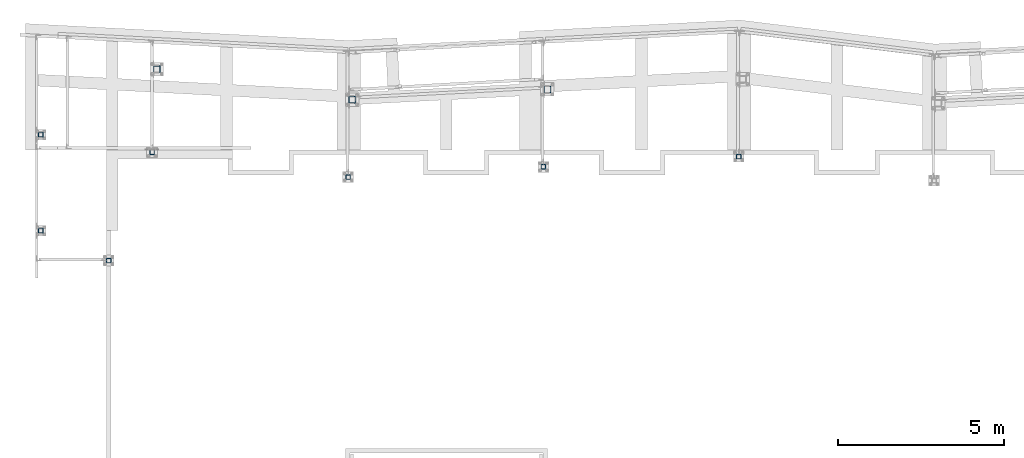
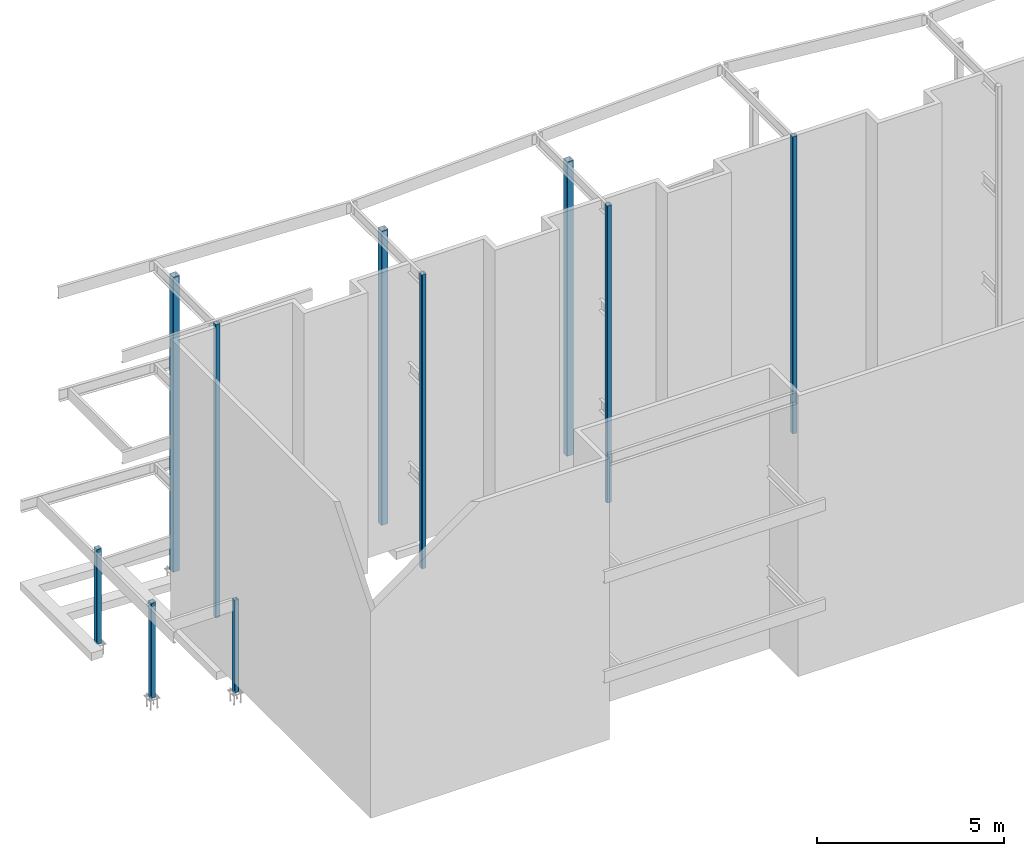
# One storey, part 1 of 89: 10 columns.
"""IFC4 building model written with IfcOpenShell, lengths in feet."""

from ifc_helpers import new_model, entity, si_unit, converted_unit, derived_unit, direction, frame, origin, place, context, subcontext, project, spatial, polyline, outline, extrude, boolean, source, transform, mapped, material, type_object, type_shapes, element, save


model = new_model("IFC4")

# Units and contexts
model_context = context("Model", 3, precision=0.0001, world=origin(), true_north=direction((6.12303176911189e-17, 1.0)))
body_context = subcontext(model_context, "Body", "Model", "MODEL_VIEW")
ifc_project = project(units=[converted_unit("LENGTHUNIT", "FOOT", entity("IfcRatioMeasure", 0.3048), si_unit("LENGTHUNIT", "METRE"), dimensions=[1, 0, 0, 0, 0, 0, 0]), converted_unit("AREAUNIT", "SQUARE FOOT", entity("IfcRatioMeasure", 0.09290304), si_unit("AREAUNIT", "SQUARE_METRE"), dimensions=[2, 0, 0, 0, 0, 0, 0]), converted_unit("VOLUMEUNIT", "CUBIC FOOT", entity("IfcRatioMeasure", 0.028316846592), si_unit("VOLUMEUNIT", "CUBIC_METRE"), dimensions=[3, 0, 0, 0, 0, 0, 0]), si_unit("PLANEANGLEUNIT", "RADIAN"), si_unit("MASSUNIT", "GRAM", prefix="KILO"), derived_unit("MASSDENSITYUNIT", [(si_unit("MASSUNIT", "GRAM", prefix="KILO"), 1), (si_unit("LENGTHUNIT", "METRE"), -3)]), derived_unit("MOMENTOFINERTIAUNIT", [(si_unit("LENGTHUNIT", "METRE"), 4)]), si_unit("TIMEUNIT", "SECOND"), si_unit("FREQUENCYUNIT", "HERTZ"), si_unit("THERMODYNAMICTEMPERATUREUNIT", "DEGREE_CELSIUS"), derived_unit("THERMALTRANSMITTANCEUNIT", [(si_unit("MASSUNIT", "GRAM", prefix="KILO"), 1), (si_unit("THERMODYNAMICTEMPERATUREUNIT", "KELVIN"), -1), (si_unit("TIMEUNIT", "SECOND"), -3)]), derived_unit("VOLUMETRICFLOWRATEUNIT", [(si_unit("LENGTHUNIT", "METRE"), 3), (si_unit("TIMEUNIT", "SECOND"), -1)]), si_unit("ELECTRICCURRENTUNIT", "AMPERE"), si_unit("ELECTRICVOLTAGEUNIT", "VOLT"), si_unit("POWERUNIT", "WATT"), si_unit("FORCEUNIT", "NEWTON"), si_unit("ILLUMINANCEUNIT", "LUX"), si_unit("LUMINOUSFLUXUNIT", "LUMEN"), si_unit("LUMINOUSINTENSITYUNIT", "CANDELA"), derived_unit("USERDEFINED", [(si_unit("MASSUNIT", "GRAM", prefix="KILO"), -1), (si_unit("LENGTHUNIT", "METRE"), -2), (si_unit("TIMEUNIT", "SECOND"), 3), (si_unit("LUMINOUSFLUXUNIT", "LUMEN"), 1)]), derived_unit("LINEARVELOCITYUNIT", [(si_unit("LENGTHUNIT", "METRE"), 1), (si_unit("TIMEUNIT", "SECOND"), -1)]), si_unit("PRESSUREUNIT", "PASCAL"), derived_unit("USERDEFINED", [(si_unit("LENGTHUNIT", "METRE"), -2), (si_unit("MASSUNIT", "GRAM", prefix="KILO"), 1), (si_unit("TIMEUNIT", "SECOND"), -2)]), derived_unit("LINEARFORCEUNIT", [(si_unit("MASSUNIT", "GRAM", prefix="KILO"), 1), (si_unit("LENGTHUNIT", "METRE"), 1), (si_unit("TIMEUNIT", "SECOND"), -2), (si_unit("LENGTHUNIT", "METRE"), -1)]), derived_unit("PLANARFORCEUNIT", [(si_unit("MASSUNIT", "GRAM", prefix="KILO"), 1), (si_unit("LENGTHUNIT", "METRE"), 1), (si_unit("TIMEUNIT", "SECOND"), -2), (si_unit("LENGTHUNIT", "METRE"), -2)])], contexts=[model_context])

# Site, building, storey
site_placement = place(None, origin())
site = spatial("IfcSite", under=ifc_project, at=site_placement, CompositionType="ELEMENT")
building_placement = place(site_placement, frame((-472.238160486, -49.138065117, 0.0)))
building = spatial("IfcBuilding", under=site, at=building_placement, CompositionType="ELEMENT")
storey_placement = place(building_placement, origin())
storey = spatial("IfcBuildingStorey", under=building, at=storey_placement, Name="Level 1", CompositionType="ELEMENT", Elevation=0.0)

# Columns
ifc_material = material(Name="Color 7719", Category="Materials")
column_type_1 = type_object("IfcColumnType", Name="hss17", PredefinedType="COLUMN")
shared_shape_1 = source(origin(), body_context, "Body", "CSG", [
    boolean("DIFFERENCE", extrude(outline(polyline([(-0.270833333333371, -0.333333333333371), (0.270833333333371, -0.333333333333371), (0.294751047856153, -0.328575804115331), (0.315027507157538, -0.315027507157509), (0.328575804115303, -0.294751047856181), (0.333333333333371, -0.270833333333371), (0.333333333333371, 0.270833333333314), (0.328575804115303, 0.294751047856124), (0.315027507157538, 0.315027507157453), (0.294751047856153, 0.328575804115275), (0.270833333333371, 0.333333333333314), (-0.270833333333371, 0.333333333333314), (-0.294751047856153, 0.328575804115275), (-0.315027507157538, 0.315027507157453), (-0.328575804115303, 0.294751047856124), (-0.333333333333371, 0.270833333333314), (-0.333333333333371, -0.270833333333371), (-0.328575804115303, -0.294751047856181), (-0.315027507157538, -0.315027507157509), (-0.294751047856153, -0.328575804115331), (-0.270833333333371, -0.333333333333371)])), frame((211.5, 1016.0, -0.479166666666668), z_axis=(0.0, 0.0, 1.0), x_axis=(0.0, -1.0, 0.0)), (0.0, 0.0, 1.0), 31.5416666666667), extrude(outline(polyline([(-0.270833333333599, -0.302083333333343), (0.270833333333144, -0.302083333333343), (0.282792190594478, -0.299704568724309), (0.29293042024517, -0.292930420245426), (0.29970456872411, -0.282792190594733), (0.302083333333144, -0.270833333333343), (0.302083333333144, 0.270833333333343), (0.29970456872411, 0.282792190594733), (0.29293042024517, 0.292930420245426), (0.282792190594478, 0.299704568724309), (0.270833333333144, 0.302083333333343), (-0.270833333333599, 0.302083333333343), (-0.282792190594932, 0.299704568724309), (-0.292930420245625, 0.292930420245426), (-0.299704568724565, 0.282792190594733), (-0.302083333333599, 0.270833333333343), (-0.302083333333599, -0.270833333333343), (-0.299704568724565, -0.282792190594733), (-0.292930420245625, -0.292930420245426), (-0.282792190594932, -0.299704568724309), (-0.270833333333599, -0.302083333333343)])), frame((211.5, 1016.0, 31.0625), z_axis=(0.0, 0.0, -1.0), x_axis=(0.0, -1.0, 0.0)), (0.0, 0.0, 1.0), 31.5416666666667)),
])
type_shapes(column_type_1, [shared_shape_1])
column_1_placement = place(building_placement, origin())
element("IfcColumn", 1, at=column_1_placement, inside=storey, type_object=column_type_1, material=ifc_material, Name="hss17:hss17", ObjectType="hss17:hss17", PredefinedType="COLUMN", context=body_context, shape_type="MappedRepresentation", body=[
    mapped(shared_shape_1, transform((0.0, 0.0, 0.0), scale=1.0)),
])
column_type_2 = type_object("IfcColumnType", Name="hss24", PredefinedType="COLUMN")
shared_shape_2 = source(origin(), body_context, "Body", "CSG", [
    boolean("DIFFERENCE", extrude(outline(polyline([(-0.187499999999886, -0.250000000000028), (0.187500000000114, -0.250000000000028), (0.211417714522895, -0.245242470781989), (0.23169417382428, -0.231694173824195), (0.245242470782046, -0.211417714522838), (0.250000000000114, -0.187500000000028), (0.250000000000114, 0.187499999999972), (0.245242470782046, 0.211417714522781), (0.23169417382428, 0.231694173824138), (0.211417714522895, 0.245242470781932), (0.187500000000114, 0.249999999999972), (-0.187499999999886, 0.249999999999972), (-0.211417714522668, 0.245242470781932), (-0.231694173824053, 0.231694173824138), (-0.245242470781818, 0.211417714522781), (-0.249999999999886, 0.187499999999972), (-0.249999999999886, -0.187500000000028), (-0.245242470781818, -0.211417714522838), (-0.231694173824053, -0.231694173824195), (-0.211417714522668, -0.245242470781989), (-0.187499999999886, -0.250000000000028)])), frame((200.0, 1009.5, -0.291666666666667), z_axis=(0.0, 0.0, 1.0), x_axis=(0.0, -1.0, 0.0)), (0.0, 0.0, 1.0), 10.1458333333333), extrude(outline(polyline([(-0.1875, -0.218749999999972), (0.1875, -0.218749999999972), (0.199458857261448, -0.216371235390938), (0.209597086912027, -0.209597086912055), (0.216371235390966, -0.199458857261391), (0.21875, -0.187499999999972), (0.21875, 0.187500000000028), (0.216371235390966, 0.199458857261448), (0.209597086912027, 0.209597086912112), (0.199458857261448, 0.216371235390994), (0.1875, 0.218750000000028), (-0.1875, 0.218750000000028), (-0.199458857261448, 0.216371235390994), (-0.209597086912027, 0.209597086912112), (-0.216371235390966, 0.199458857261448), (-0.21875, 0.187500000000028), (-0.21875, -0.187499999999972), (-0.216371235390966, -0.199458857261391), (-0.209597086912027, -0.209597086912055), (-0.199458857261448, -0.216371235390938), (-0.1875, -0.218749999999972)])), frame((200.0, 1009.5, 9.85416666666663), z_axis=(0.0, 0.0, -1.0), x_axis=(0.0, -1.0, 0.0)), (0.0, 0.0, 1.0), 10.1458333333333)),
])
type_shapes(column_type_2, [shared_shape_2])
column_2_placement = place(building_placement, origin())
element("IfcColumn", 2, at=column_2_placement, inside=storey, type_object=column_type_2, material=ifc_material, Name="hss24:hss24", ObjectType="hss24:hss24", PredefinedType="COLUMN", context=body_context, shape_type="MappedRepresentation", body=[
    mapped(shared_shape_2, transform((0.0, 0.0, 0.0), scale=1.0)),
])
column_type_3 = type_object("IfcColumnType", Name="hss24", PredefinedType="COLUMN")
shared_shape_3 = source(origin(), body_context, "Body", "CSG", [
    boolean("DIFFERENCE", extrude(outline(polyline([(-0.187499999999886, -0.250000000000028), (0.187500000000114, -0.250000000000028), (0.211417714522895, -0.245242470781989), (0.23169417382428, -0.231694173824195), (0.245242470782046, -0.211417714522838), (0.250000000000114, -0.187500000000028), (0.250000000000114, 0.187499999999972), (0.245242470782046, 0.211417714522781), (0.23169417382428, 0.231694173824138), (0.211417714522895, 0.245242470781932), (0.187500000000114, 0.249999999999972), (-0.187499999999886, 0.249999999999972), (-0.211417714522668, 0.245242470781932), (-0.231694173824053, 0.231694173824138), (-0.245242470781818, 0.211417714522781), (-0.249999999999886, 0.187499999999972), (-0.249999999999886, -0.187500000000028), (-0.245242470781818, -0.211417714522838), (-0.231694173824053, -0.231694173824195), (-0.211417714522668, -0.245242470781989), (-0.187499999999886, -0.250000000000028)])), frame((200.0, 1000.0, -0.291666666666667), z_axis=(0.0, 0.0, 1.0), x_axis=(0.0, -1.0, 0.0)), (0.0, 0.0, 1.0), 10.1458333333333), extrude(outline(polyline([(-0.1875, -0.218749999999972), (0.1875, -0.218749999999972), (0.199458857261448, -0.216371235390938), (0.209597086912027, -0.209597086912055), (0.216371235390966, -0.199458857261391), (0.21875, -0.187499999999972), (0.21875, 0.187500000000028), (0.216371235390966, 0.199458857261448), (0.209597086912027, 0.209597086912112), (0.199458857261448, 0.216371235390994), (0.1875, 0.218750000000028), (-0.1875, 0.218750000000028), (-0.199458857261448, 0.216371235390994), (-0.209597086912027, 0.209597086912112), (-0.216371235390966, 0.199458857261448), (-0.21875, 0.187500000000028), (-0.21875, -0.187499999999972), (-0.216371235390966, -0.199458857261391), (-0.209597086912027, -0.209597086912055), (-0.199458857261448, -0.216371235390938), (-0.1875, -0.218749999999972)])), frame((200.0, 1000.0, 9.85416666666663), z_axis=(0.0, 0.0, -1.0), x_axis=(0.0, -1.0, 0.0)), (0.0, 0.0, 1.0), 10.1458333333333)),
])
type_shapes(column_type_3, [shared_shape_3])
column_3_placement = place(building_placement, origin())
element("IfcColumn", 3, at=column_3_placement, inside=storey, type_object=column_type_3, material=ifc_material, Name="hss24 5016:hss24 5016", ObjectType="hss24 5016:hss24 5016", PredefinedType="COLUMN", context=body_context, shape_type="MappedRepresentation", body=[
    mapped(shared_shape_3, transform((0.0, 0.0, 0.0), scale=1.0)),
])
column_type_4 = type_object("IfcColumnType", Name="hss14", PredefinedType="COLUMN")
shared_shape_4 = source(origin(), body_context, "Body", "CSG", [
    boolean("DIFFERENCE", extrude(outline(polyline([(-0.166666666666515, -0.229166666666657), (0.166666666666742, -0.229166666666657), (0.190584381189638, -0.224409137448617), (0.210860840490909, -0.210860840490824), (0.224409137448788, -0.190584381189495), (0.229166666666742, -0.166666666666657), (0.229166666666742, 0.166666666666657), (0.224409137448788, 0.190584381189495), (0.210860840490909, 0.210860840490824), (0.190584381189638, 0.224409137448617), (0.166666666666742, 0.229166666666657), (-0.166666666666515, 0.229166666666657), (-0.19058438118941, 0.224409137448617), (-0.210860840490682, 0.210860840490824), (-0.224409137448561, 0.190584381189495), (-0.229166666666515, 0.166666666666657), (-0.229166666666515, -0.166666666666657), (-0.224409137448561, -0.190584381189495), (-0.210860840490682, -0.210860840490824), (-0.19058438118941, -0.224409137448617), (-0.166666666666515, -0.229166666666657)])), frame((211.026041666667, 1007.77083333333, -0.291666666666668), z_axis=(0.0, 0.0, 1.0), x_axis=(0.0, -1.0, 0.0)), (0.0, 0.0, 1.0), 31.3541666666667), extrude(outline(polyline([(-0.166666666666856, -0.197916666666657), (0.166666666666401, -0.197916666666657), (0.178625523927849, -0.195537902057652), (0.188763753578542, -0.188763753578741), (0.195537902057367, -0.178625523928076), (0.197916666666401, -0.166666666666657), (0.197916666666401, 0.166666666666657), (0.195537902057367, 0.178625523928076), (0.188763753578542, 0.188763753578741), (0.178625523927849, 0.195537902057652), (0.166666666666401, 0.197916666666657), (-0.166666666666856, 0.197916666666657), (-0.178625523928304, 0.195537902057652), (-0.188763753578996, 0.188763753578741), (-0.195537902057822, 0.178625523928076), (-0.197916666666856, 0.166666666666657), (-0.197916666666856, -0.166666666666657), (-0.195537902057822, -0.178625523928076), (-0.188763753578996, -0.188763753578741), (-0.178625523928304, -0.195537902057652), (-0.166666666666856, -0.197916666666657)])), frame((211.026041666667, 1007.77083333333, 31.0625), z_axis=(0.0, 0.0, -1.0), x_axis=(0.0, -1.0, 0.0)), (0.0, 0.0, 1.0), 31.3541666666667)),
])
type_shapes(column_type_4, [shared_shape_4])
column_4_placement = place(building_placement, origin())
element("IfcColumn", 4, at=column_4_placement, inside=storey, type_object=column_type_4, material=ifc_material, Name="hss14:hss14", ObjectType="hss14:hss14", PredefinedType="COLUMN", context=body_context, shape_type="MappedRepresentation", body=[
    mapped(shared_shape_4, transform((0.0, 0.0, 0.0), scale=1.0)),
])
column_type_5 = type_object("IfcColumnType", Name="hss15", PredefinedType="COLUMN")
shared_shape_5 = source(origin(), body_context, "Body", "CSG", [
    boolean("DIFFERENCE", extrude(outline(polyline([(-0.166666666666515, -0.229166666666686), (0.166666666666742, -0.229166666666686), (0.190584381189638, -0.224409137448646), (0.210860840490909, -0.210860840490852), (0.224409137448788, -0.190584381189524), (0.229166666666742, -0.166666666666686), (0.229166666666742, 0.166666666666629), (0.224409137448788, 0.190584381189467), (0.210860840490909, 0.210860840490795), (0.190584381189638, 0.224409137448589), (0.166666666666742, 0.229166666666629), (-0.166666666666515, 0.229166666666629), (-0.19058438118941, 0.224409137448589), (-0.210860840490682, 0.210860840490795), (-0.224409137448561, 0.190584381189467), (-0.229166666666515, 0.166666666666629), (-0.229166666666515, -0.166666666666686), (-0.224409137448561, -0.190584381189524), (-0.210860840490682, -0.210860840490852), (-0.19058438118941, -0.224409137448646), (-0.166666666666515, -0.229166666666686)])), frame((230.4375, 1005.3125, -0.375), z_axis=(0.0, 0.0, 1.0), x_axis=(0.0, -1.0, 0.0)), (0.0, 0.0, 1.0), 31.4375), extrude(outline(polyline([(-0.166666666666515, -0.197916666666714), (0.166666666666742, -0.197916666666714), (0.17862552392819, -0.195537902057708), (0.188763753578883, -0.188763753578797), (0.195537902057708, -0.178625523928133), (0.197916666666742, -0.166666666666714), (0.197916666666742, 0.1666666666666), (0.195537902057708, 0.178625523928019), (0.188763753578883, 0.188763753578684), (0.17862552392819, 0.195537902057595), (0.166666666666742, 0.1979166666666), (-0.166666666666515, 0.1979166666666), (-0.178625523927963, 0.195537902057595), (-0.188763753578655, 0.188763753578684), (-0.195537902057481, 0.178625523928019), (-0.197916666666515, 0.1666666666666), (-0.197916666666515, -0.166666666666714), (-0.195537902057481, -0.178625523928133), (-0.188763753578655, -0.188763753578797), (-0.178625523927963, -0.195537902057708), (-0.166666666666515, -0.197916666666714)])), frame((230.4375, 1005.3125, 31.0625), z_axis=(0.0, 0.0, -1.0), x_axis=(0.0, -1.0, 0.0)), (0.0, 0.0, 1.0), 31.4375)),
])
type_shapes(column_type_5, [shared_shape_5])
column_5_placement = place(building_placement, origin())
element("IfcColumn", 5, at=column_5_placement, inside=storey, type_object=column_type_5, material=ifc_material, Name="hss15:hss15", ObjectType="hss15:hss15", PredefinedType="COLUMN", context=body_context, shape_type="MappedRepresentation", body=[
    mapped(shared_shape_5, transform((0.0, 0.0, 0.0), scale=1.0)),
])
column_type_6 = type_object("IfcColumnType", Name="hss16", PredefinedType="COLUMN")
shared_shape_6 = source(origin(), body_context, "Body", "CSG", [
    boolean("DIFFERENCE", extrude(outline(polyline([(-0.166666666666515, -0.229166666666686), (0.166666666666742, -0.229166666666686), (0.190584381189638, -0.224409137448646), (0.210860840490909, -0.210860840490852), (0.224409137448788, -0.190584381189524), (0.229166666666742, -0.166666666666686), (0.229166666666742, 0.166666666666629), (0.224409137448788, 0.190584381189467), (0.210860840490909, 0.210860840490795), (0.190584381189638, 0.224409137448589), (0.166666666666742, 0.229166666666629), (-0.166666666666515, 0.229166666666629), (-0.19058438118941, 0.224409137448589), (-0.210860840490682, 0.210860840490795), (-0.224409137448561, 0.190584381189467), (-0.229166666666515, 0.166666666666629), (-0.229166666666515, -0.166666666666686), (-0.224409137448561, -0.190584381189524), (-0.210860840490682, -0.210860840490852), (-0.19058438118941, -0.224409137448646), (-0.166666666666515, -0.229166666666686)])), frame((249.770833333333, 1006.328125, -0.708333333333334), z_axis=(0.0, 0.0, 1.0), x_axis=(0.0, -1.0, 0.0)), (0.0, 0.0, 1.0), 31.7708333333333), extrude(outline(polyline([(-0.166666666666515, -0.197916666666686), (0.166666666666742, -0.197916666666686), (0.17862552392819, -0.19553790205768), (0.188763753578883, -0.188763753578769), (0.195537902057708, -0.178625523928105), (0.197916666666742, -0.166666666666686), (0.197916666666742, 0.166666666666629), (0.195537902057708, 0.178625523928048), (0.188763753578883, 0.188763753578712), (0.17862552392819, 0.195537902057623), (0.166666666666742, 0.197916666666629), (-0.166666666666515, 0.197916666666629), (-0.178625523927963, 0.195537902057623), (-0.188763753578655, 0.188763753578712), (-0.195537902057481, 0.178625523928048), (-0.197916666666515, 0.166666666666629), (-0.197916666666515, -0.166666666666686), (-0.195537902057481, -0.178625523928105), (-0.188763753578655, -0.188763753578769), (-0.178625523927963, -0.19553790205768), (-0.166666666666515, -0.197916666666686)])), frame((249.770833333333, 1006.328125, 31.0625), z_axis=(0.0, 0.0, -1.0), x_axis=(0.0, -1.0, 0.0)), (0.0, 0.0, 1.0), 31.7708333333333)),
])
type_shapes(column_type_6, [shared_shape_6])
column_6_placement = place(building_placement, origin())
element("IfcColumn", 6, at=column_6_placement, inside=storey, type_object=column_type_6, material=ifc_material, Name="hss16:hss16", ObjectType="hss16:hss16", PredefinedType="COLUMN", context=body_context, shape_type="MappedRepresentation", body=[
    mapped(shared_shape_6, transform((0.0, 0.0, 0.0), scale=1.0)),
])
column_type_7 = type_object("IfcColumnType", Name="hss16", PredefinedType="COLUMN")
shared_shape_7 = source(origin(), body_context, "Body", "CSG", [
    boolean("DIFFERENCE", extrude(outline(polyline([(-0.166666666666629, -0.229166666666742), (0.166666666666629, -0.229166666666742), (0.190584381189524, -0.224409137448674), (0.210860840490795, -0.210860840490909), (0.224409137448674, -0.190584381189524), (0.229166666666629, -0.166666666666742), (0.229166666666629, 0.166666666666629), (0.224409137448674, 0.19058438118941), (0.210860840490795, 0.210860840490795), (0.190584381189524, 0.224409137448561), (0.166666666666629, 0.229166666666629), (-0.166666666666629, 0.229166666666629), (-0.190584381189524, 0.224409137448561), (-0.210860840490795, 0.210860840490795), (-0.224409137448674, 0.19058438118941), (-0.229166666666629, 0.166666666666629), (-0.229166666666629, -0.166666666666742), (-0.224409137448674, -0.190584381189524), (-0.210860840490795, -0.210860840490909), (-0.190584381189524, -0.224409137448674), (-0.166666666666629, -0.229166666666742)])), frame((269.104166666667, 1007.33854166667, -0.708333333333334), z_axis=(0.0, 0.0, 1.0), x_axis=(0.0, -1.0, 0.0)), (0.0, 0.0, 1.0), 31.7708333333333), extrude(outline(polyline([(-0.166666666666629, -0.197916666666686), (0.166666666666629, -0.197916666666686), (0.178625523928076, -0.195537902057652), (0.188763753578769, -0.188763753578769), (0.195537902057595, -0.178625523928076), (0.197916666666629, -0.166666666666686), (0.197916666666629, 0.166666666666686), (0.195537902057595, 0.178625523928076), (0.188763753578769, 0.188763753578769), (0.178625523928076, 0.195537902057652), (0.166666666666629, 0.197916666666686), (-0.166666666666629, 0.197916666666686), (-0.178625523928076, 0.195537902057652), (-0.188763753578769, 0.188763753578769), (-0.195537902057595, 0.178625523928076), (-0.197916666666629, 0.166666666666686), (-0.197916666666629, -0.166666666666686), (-0.195537902057595, -0.178625523928076), (-0.188763753578769, -0.188763753578769), (-0.178625523928076, -0.195537902057652), (-0.166666666666629, -0.197916666666686)])), frame((269.104166666667, 1007.33854166667, 31.0625), z_axis=(0.0, 0.0, -1.0), x_axis=(0.0, -1.0, 0.0)), (0.0, 0.0, 1.0), 31.7708333333333)),
])
type_shapes(column_type_7, [shared_shape_7])
column_7_placement = place(building_placement, origin())
element("IfcColumn", 7, at=column_7_placement, inside=storey, type_object=column_type_7, material=ifc_material, Name="hss16 5020:hss16 5020", ObjectType="hss16 5020:hss16 5020", PredefinedType="COLUMN", context=body_context, shape_type="MappedRepresentation", body=[
    mapped(shared_shape_7, transform((0.0, 0.0, 0.0), scale=1.0)),
])
column_type_8 = type_object("IfcColumnType", Name="hss21", PredefinedType="COLUMN")
shared_shape_8 = source(origin(), body_context, "Body", "CSG", [
    boolean("DIFFERENCE", extrude(outline(polyline([(-0.270833333333371, -0.333333333333343), (0.270833333333371, -0.333333333333343), (0.294751047856153, -0.328575804115303), (0.315027507157538, -0.315027507157481), (0.328575804115303, -0.294751047856153), (0.333333333333371, -0.270833333333343), (0.333333333333371, 0.270833333333343), (0.328575804115303, 0.294751047856153), (0.315027507157538, 0.315027507157481), (0.294751047856153, 0.328575804115303), (0.270833333333371, 0.333333333333343), (-0.270833333333371, 0.333333333333343), (-0.294751047856153, 0.328575804115303), (-0.315027507157538, 0.315027507157481), (-0.328575804115303, 0.294751047856153), (-0.333333333333371, 0.270833333333343), (-0.333333333333371, -0.270833333333343), (-0.328575804115303, -0.294751047856153), (-0.315027507157538, -0.315027507157481), (-0.294751047856153, -0.328575804115303), (-0.270833333333371, -0.333333333333343)])), frame((250.166666666667, 1013.984375, -0.395833333333334), z_axis=(0.0, 0.0, 1.0), x_axis=(0.0, -1.0, 0.0)), (0.0, 0.0, 1.0), 31.4583333333333), extrude(outline(polyline([(-0.270833333333599, -0.302083333333371), (0.270833333333144, -0.302083333333371), (0.282792190594478, -0.299704568724337), (0.29293042024517, -0.292930420245455), (0.29970456872411, -0.282792190594762), (0.302083333333144, -0.270833333333371), (0.302083333333144, 0.270833333333314), (0.29970456872411, 0.282792190594705), (0.29293042024517, 0.292930420245398), (0.282792190594478, 0.29970456872428), (0.270833333333144, 0.302083333333314), (-0.270833333333599, 0.302083333333314), (-0.282792190594932, 0.29970456872428), (-0.292930420245625, 0.292930420245398), (-0.299704568724565, 0.282792190594705), (-0.302083333333599, 0.270833333333314), (-0.302083333333599, -0.270833333333371), (-0.299704568724565, -0.282792190594762), (-0.292930420245625, -0.292930420245455), (-0.282792190594932, -0.299704568724337), (-0.270833333333599, -0.302083333333371)])), frame((250.166666666667, 1013.984375, 31.0625), z_axis=(0.0, 0.0, -1.0), x_axis=(0.0, -1.0, 0.0)), (0.0, 0.0, 1.0), 31.4583333333333)),
])
type_shapes(column_type_8, [shared_shape_8])
column_8_placement = place(building_placement, origin())
element("IfcColumn", 8, at=column_8_placement, inside=storey, type_object=column_type_8, material=ifc_material, Name="hss21 5028:hss21 5028", ObjectType="hss21 5028:hss21 5028", PredefinedType="COLUMN", context=body_context, shape_type="MappedRepresentation", body=[
    mapped(shared_shape_8, transform((0.0, 0.0, 0.0), scale=1.0)),
])
column_type_9 = type_object("IfcColumnType", Name="hss21", PredefinedType="COLUMN")
shared_shape_9 = source(origin(), body_context, "Body", "CSG", [
    boolean("DIFFERENCE", extrude(outline(polyline([(-0.270833333333371, -0.333333333333371), (0.270833333333371, -0.333333333333371), (0.294751047856153, -0.328575804115331), (0.315027507157538, -0.315027507157509), (0.328575804115303, -0.294751047856181), (0.333333333333371, -0.270833333333371), (0.333333333333371, 0.270833333333314), (0.328575804115303, 0.294751047856124), (0.315027507157538, 0.315027507157453), (0.294751047856153, 0.328575804115275), (0.270833333333371, 0.333333333333314), (-0.270833333333371, 0.333333333333314), (-0.294751047856153, 0.328575804115275), (-0.315027507157538, 0.315027507157453), (-0.328575804115303, 0.294751047856124), (-0.333333333333371, 0.270833333333314), (-0.333333333333371, -0.270833333333371), (-0.328575804115303, -0.294751047856181), (-0.315027507157538, -0.315027507157509), (-0.294751047856153, -0.328575804115331), (-0.270833333333371, -0.333333333333371)])), frame((230.833333333333, 1012.96875, -0.395833333333334), z_axis=(0.0, 0.0, 1.0), x_axis=(0.0, -1.0, 0.0)), (0.0, 0.0, 1.0), 31.4583333333333), extrude(outline(polyline([(-0.270833333333599, -0.302083333333314), (0.270833333333144, -0.302083333333314), (0.282792190594478, -0.29970456872428), (0.29293042024517, -0.292930420245398), (0.29970456872411, -0.282792190594705), (0.302083333333144, -0.270833333333314), (0.302083333333144, 0.270833333333371), (0.29970456872411, 0.282792190594762), (0.29293042024517, 0.292930420245455), (0.282792190594478, 0.299704568724337), (0.270833333333144, 0.302083333333371), (-0.270833333333599, 0.302083333333371), (-0.282792190594932, 0.299704568724337), (-0.292930420245625, 0.292930420245455), (-0.299704568724565, 0.282792190594762), (-0.302083333333599, 0.270833333333371), (-0.302083333333599, -0.270833333333314), (-0.299704568724565, -0.282792190594705), (-0.292930420245625, -0.292930420245398), (-0.282792190594932, -0.29970456872428), (-0.270833333333599, -0.302083333333314)])), frame((230.833333333333, 1012.96875, 31.0625), z_axis=(0.0, 0.0, -1.0), x_axis=(0.0, -1.0, 0.0)), (0.0, 0.0, 1.0), 31.4583333333333)),
])
type_shapes(column_type_9, [shared_shape_9])
column_9_placement = place(building_placement, origin())
element("IfcColumn", 9, at=column_9_placement, inside=storey, type_object=column_type_9, material=ifc_material, Name="hss21 5029:hss21 5029", ObjectType="hss21 5029:hss21 5029", PredefinedType="COLUMN", context=body_context, shape_type="MappedRepresentation", body=[
    mapped(shared_shape_9, transform((0.0, 0.0, 0.0), scale=1.0)),
])
column_type_10 = type_object("IfcColumnType", Name="hss23", PredefinedType="COLUMN")
shared_shape_10 = source(origin(), body_context, "Body", "CSG", [
    boolean("DIFFERENCE", extrude(outline(polyline([(-0.166666666666629, -0.229166666666657), (0.166666666666629, -0.229166666666657), (0.190584381189524, -0.224409137448617), (0.210860840490795, -0.210860840490824), (0.224409137448674, -0.190584381189495), (0.229166666666629, -0.166666666666657), (0.229166666666629, 0.166666666666657), (0.224409137448674, 0.190584381189495), (0.210860840490795, 0.210860840490824), (0.190584381189524, 0.224409137448617), (0.166666666666629, 0.229166666666657), (-0.166666666666629, 0.229166666666657), (-0.190584381189524, 0.224409137448617), (-0.210860840490795, 0.210860840490824), (-0.224409137448674, 0.190584381189495), (-0.229166666666629, 0.166666666666657), (-0.229166666666629, -0.166666666666657), (-0.224409137448674, -0.190584381189495), (-0.210860840490795, -0.210860840490824), (-0.190584381189524, -0.224409137448617), (-0.166666666666629, -0.229166666666657)])), frame((206.729166666667, 997.052083333333, -0.291666666666667), z_axis=(0.0, 0.0, 1.0), x_axis=(0.0, -1.0, 0.0)), (0.0, 0.0, 1.0), 9.875), extrude(outline(polyline([(-0.166666666666629, -0.197916666666657), (0.166666666666629, -0.197916666666657), (0.178625523928076, -0.195537902057652), (0.188763753578769, -0.188763753578741), (0.195537902057595, -0.178625523928076), (0.197916666666629, -0.166666666666657), (0.197916666666629, 0.166666666666657), (0.195537902057595, 0.178625523928076), (0.188763753578769, 0.188763753578741), (0.178625523928076, 0.195537902057652), (0.166666666666629, 0.197916666666657), (-0.166666666666629, 0.197916666666657), (-0.178625523928076, 0.195537902057652), (-0.188763753578769, 0.188763753578741), (-0.195537902057595, 0.178625523928076), (-0.197916666666629, 0.166666666666657), (-0.197916666666629, -0.166666666666657), (-0.195537902057595, -0.178625523928076), (-0.188763753578769, -0.188763753578741), (-0.178625523928076, -0.195537902057652), (-0.166666666666629, -0.197916666666657)])), frame((206.729166666667, 997.052083333333, 9.58333333333333), z_axis=(0.0, 0.0, -1.0), x_axis=(0.0, -1.0, 0.0)), (0.0, 0.0, 1.0), 9.875)),
])
type_shapes(column_type_10, [shared_shape_10])
column_10_placement = place(building_placement, origin())
element("IfcColumn", 10, at=column_10_placement, inside=storey, type_object=column_type_10, material=ifc_material, Name="hss23:hss23", ObjectType="hss23:hss23", PredefinedType="COLUMN", context=body_context, shape_type="MappedRepresentation", body=[
    mapped(shared_shape_10, transform((0.0, 0.0, 0.0), scale=1.0)),
])

save(model, "model.ifc")
